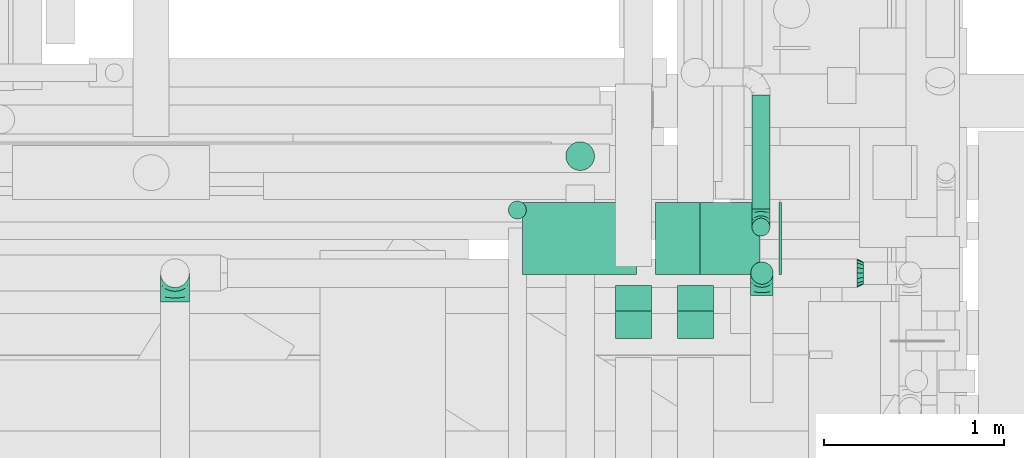
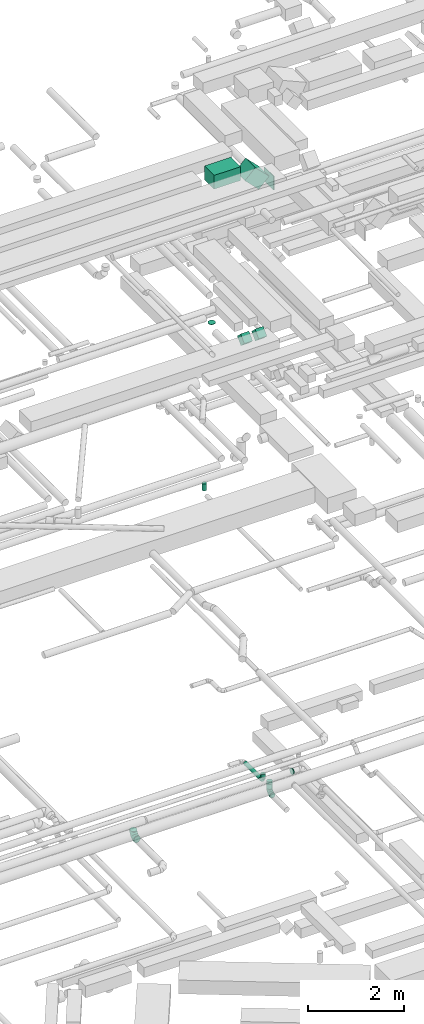
# One storey, part 107 of 337: 10 flow segments, 5 flow fittings.
"""IFC2X3 building model written with IfcOpenShell, lengths in millimetres."""

from ifc_helpers import new_model, entity, si_unit, converted_unit, derived_unit, direction, frame, frame_2d, origin, origin_2d_with_axis, place, context, subcontext, project, spatial, rectangle, circle, extrude, faceted_brep, source, transform, mapped, material, type_object, type_shapes, element, save


model = new_model("IFC2X3")

# Units and contexts
model_context = context("Model", 3, precision=0.01, world=origin(), true_north=direction((6.12303176911189e-17, 1.0)))
body_context = subcontext(model_context, "Body", "Model", "MODEL_VIEW")
ifc_project = project(units=[si_unit("LENGTHUNIT", "METRE", prefix="MILLI"), si_unit("AREAUNIT", "SQUARE_METRE"), si_unit("VOLUMEUNIT", "CUBIC_METRE"), converted_unit("PLANEANGLEUNIT", "DEGREE", entity("IfcRatioMeasure", 0.0174532925199433), si_unit("PLANEANGLEUNIT", "RADIAN"), dimensions=[0, 0, 0, 0, 0, 0, 0]), si_unit("MASSUNIT", "GRAM", prefix="KILO"), derived_unit("MASSDENSITYUNIT", [(si_unit("MASSUNIT", "GRAM", prefix="KILO"), 1), (si_unit("LENGTHUNIT", "METRE"), -3)]), derived_unit("MOMENTOFINERTIAUNIT", [(si_unit("LENGTHUNIT", "METRE"), 4)]), si_unit("TIMEUNIT", "SECOND"), si_unit("FREQUENCYUNIT", "HERTZ"), si_unit("THERMODYNAMICTEMPERATUREUNIT", "DEGREE_CELSIUS"), derived_unit("THERMALTRANSMITTANCEUNIT", [(si_unit("MASSUNIT", "GRAM", prefix="KILO"), 1), (si_unit("THERMODYNAMICTEMPERATUREUNIT", "KELVIN"), -1), (si_unit("TIMEUNIT", "SECOND"), -3)]), derived_unit("VOLUMETRICFLOWRATEUNIT", [(si_unit("LENGTHUNIT", "METRE"), 3), (si_unit("TIMEUNIT", "SECOND"), -1)]), derived_unit("MASSFLOWRATEUNIT", [(si_unit("MASSUNIT", "GRAM", prefix="KILO"), 1), (si_unit("TIMEUNIT", "SECOND"), -1)]), derived_unit("ROTATIONALFREQUENCYUNIT", [(si_unit("TIMEUNIT", "SECOND"), -1)]), si_unit("ELECTRICCURRENTUNIT", "AMPERE"), si_unit("ELECTRICVOLTAGEUNIT", "VOLT"), si_unit("POWERUNIT", "WATT"), si_unit("FORCEUNIT", "NEWTON", prefix="KILO"), si_unit("ILLUMINANCEUNIT", "LUX"), si_unit("LUMINOUSFLUXUNIT", "LUMEN"), si_unit("LUMINOUSINTENSITYUNIT", "CANDELA"), derived_unit("USERDEFINED", [(si_unit("MASSUNIT", "GRAM", prefix="KILO"), -1), (si_unit("LENGTHUNIT", "METRE"), -2), (si_unit("TIMEUNIT", "SECOND"), 3), (si_unit("LUMINOUSFLUXUNIT", "LUMEN"), 1)]), derived_unit("LINEARVELOCITYUNIT", [(si_unit("LENGTHUNIT", "METRE"), 1), (si_unit("TIMEUNIT", "SECOND"), -1)]), si_unit("PRESSUREUNIT", "PASCAL"), derived_unit("USERDEFINED", [(si_unit("LENGTHUNIT", "METRE"), -2), (si_unit("MASSUNIT", "GRAM", prefix="KILO"), 1), (si_unit("TIMEUNIT", "SECOND"), -2)]), derived_unit("LINEARFORCEUNIT", [(si_unit("MASSUNIT", "GRAM", prefix="KILO"), 1), (si_unit("LENGTHUNIT", "METRE"), 1), (si_unit("TIMEUNIT", "SECOND"), -2), (si_unit("LENGTHUNIT", "METRE"), -1)]), derived_unit("PLANARFORCEUNIT", [(si_unit("MASSUNIT", "GRAM", prefix="KILO"), 1), (si_unit("LENGTHUNIT", "METRE"), 1), (si_unit("TIMEUNIT", "SECOND"), -2), (si_unit("LENGTHUNIT", "METRE"), -2)])], contexts=[model_context])

# Site, building, storey
site_placement = place(None, origin())
site = spatial("IfcSite", under=ifc_project, at=site_placement, CompositionType="ELEMENT")
building_placement = place(site_placement, origin())
building = spatial("IfcBuilding", under=site, at=building_placement, CompositionType="ELEMENT")
storey_placement = place(building_placement, origin())
storey = spatial("IfcBuildingStorey", under=building, at=storey_placement, CompositionType="ELEMENT", Elevation=0.0)

# Flow segments
duct_segment_type_1 = type_object("IfcDuctSegmentType", PredefinedType="NOTDEFINED")
flow_segment_1_placement = place(storey_placement, frame((17693.85, 12067.41, 18500.0)))
element("IfcFlowSegment", 1, at=flow_segment_1_placement, inside=storey, type_object=duct_segment_type_1, context=body_context, shape_type="SweptSolid", body=[
    extrude(rectangle(XDim=15.3805922287345, YDim=400.0, at=origin_2d_with_axis()), frame((7.69, 200.0, 0.0), z_axis=(0.0, 0.0, 1.0), x_axis=(-1.0, 0.0, 0.0)), (0.0, 0.0, 1.0), 349.999999999998),
])
flow_segment_2_placement = place(storey_placement, frame((16266.85, 12067.41, 19025.0)))
element("IfcFlowSegment", 2, at=flow_segment_2_placement, inside=storey, type_object=duct_segment_type_1, context=body_context, shape_type="SweptSolid", body=[
    extrude(rectangle(XDim=632.755592228713, YDim=400.0, at=origin_2d_with_axis()), frame((316.38, 200.0, 0.0), z_axis=(0.0, 0.0, 1.0), x_axis=(-1.0, 0.0, 0.0)), (0.0, 0.0, 1.0), 349.999999999998),
])
flow_segment_3_placement = place(storey_placement, frame((17005.67, 12067.41, 18646.45)))
element("IfcFlowSegment", 3, at=flow_segment_3_placement, inside=storey, type_object=duct_segment_type_1, context=body_context, shape_type="SweptSolid", body=[
    extrude(rectangle(XDim=350.000000000003, YDim=400.0, at=origin_2d_with_axis()), frame((123.74, 200.0, 458.36), z_axis=(0.707106781186548, 0.0, -0.707106781186548), x_axis=(0.707106781186548, 0.0, 0.707106781186548)), (0.0, 0.0, 1.0), 473.223304703305),
])
flow_segment_4_placement = place(storey_placement, frame((17130.0, 11710.77, 15002.51)))
element("IfcFlowSegment", 4, at=flow_segment_4_placement, inside=storey, type_object=duct_segment_type_1, context=body_context, shape_type="SweptSolid", body=[
    extrude(rectangle(XDim=200.000000000001, YDim=199.999999999998, at=frame_2d((0.0, 0.0), x_axis=(0.0, 1.0))), frame((100.0, 70.71, 70.71), z_axis=(0.0, 0.707106781186526, 0.707106781186569), x_axis=(-1.0, 0.0, 0.0)), (0.0, 0.0, 1.0), 217.157280798671),
])
flow_segment_5_placement = place(storey_placement, frame((16784.94, 11710.77, 15002.51)))
element("IfcFlowSegment", 5, at=flow_segment_5_placement, inside=storey, type_object=duct_segment_type_1, context=body_context, shape_type="SweptSolid", body=[
    extrude(rectangle(XDim=200.000000000003, YDim=199.999999999998, at=frame_2d((0.0, 0.0), x_axis=(0.0, 1.0))), frame((100.0, 70.71, 70.71), z_axis=(0.0, 0.70710678118652, 0.707106781186575), x_axis=(-1.0, 0.0, 0.0)), (0.0, 0.0, 1.0), 217.157280798674),
])
duct_segment_type_2 = type_object("IfcDuctSegmentType", PredefinedType="NOTDEFINED")
flow_segment_6_placement = place(storey_placement, frame((17542.06, 12430.36, 3348.4)))
element("IfcFlowSegment", 6, at=flow_segment_6_placement, inside=storey, type_object=duct_segment_type_2, context=body_context, shape_type="SweptSolid", body=[
    extrude(circle(Radius=50.0, at=origin_2d_with_axis()), frame((51.6, 0.0, 51.6), z_axis=(0.0, 1.0, 0.0), x_axis=(-1.0, 0.0, 0.0)), (0.0, 0.0, 1.0), 635.000000000009),
])
flow_segment_7_placement = place(storey_placement, frame((16185.99, 12374.09, 11200.0)))
element("IfcFlowSegment", 7, at=flow_segment_7_placement, inside=storey, type_object=duct_segment_type_2, context=body_context, shape_type="SweptSolid", body=[
    extrude(circle(Radius=50.0, at=origin_2d_with_axis()), frame((51.6, 51.6, 0.0)), (0.0, 0.0, 1.0), 169.999999999974),
])
flow_segment_8_placement = place(storey_placement, frame((16505.63, 12644.09, 15130.0)))
element("IfcFlowSegment", 8, at=flow_segment_8_placement, inside=storey, type_object=duct_segment_type_2, context=body_context, shape_type="SweptSolid", body=[
    extrude(circle(Radius=80.0, at=origin_2d_with_axis()), frame((81.6, 81.6, 0.0), z_axis=(0.0, 0.0, 1.0), x_axis=(0.0, 1.0, 0.0)), (0.0, 0.0, 1.0), 10.000064149027),
])
flow_segment_9_placement = place(storey_placement, frame((17535.1, 12010.44, 3375.0)))
element("IfcFlowSegment", 9, at=flow_segment_9_placement, inside=storey, type_object=duct_segment_type_2, context=body_context, shape_type="SweptSolid", body=[
    extrude(circle(Radius=62.5, at=origin_2d_with_axis()), frame((64.1, 64.1, 0.0), z_axis=(0.0, 0.0, 1.0), x_axis=(-1.0, 0.0, 0.0)), (0.0, 0.0, 1.0), 124.999999999998),
])
flow_segment_10_placement = place(storey_placement, frame((17542.06, 12278.76, 3500.0)))
element("IfcFlowSegment", 10, at=flow_segment_10_placement, inside=storey, type_object=duct_segment_type_2, context=body_context, shape_type="SweptSolid", body=[
    extrude(circle(Radius=50.0, at=origin_2d_with_axis()), frame((51.6, 51.6, 0.0)), (0.0, 0.0, 1.0), 84.1742430504415),
])

# Flow fittings
ifc_material = material()
duct_fitting_type_1 = type_object("IfcDuctFittingType", PredefinedType="NOTDEFINED", material=ifc_material)
shared_shape_1 = source(origin(), body_context, "Body", "Brep", [
    faceted_brep([(-160.0, 0.0, -80.0), (-160.0, -20.71, -77.27), (-160.0, -40.0, -69.28), (-160.0, -56.57, -56.57), (-160.0, -69.28, -40.0), (-160.0, -77.27, -20.71), (-160.0, -80.0, 0.0), (-160.0, -77.27, 20.71), (-160.0, -69.28, 40.0), (-160.0, -56.57, 56.57), (-160.0, -40.0, 69.28), (-160.0, -20.71, 77.27), (-160.0, 0.0, 80.0), (-160.0, 20.71, 77.27), (-160.0, 40.0, 69.28), (-160.0, 56.57, 56.57), (-160.0, 69.28, 40.0), (-160.0, 77.27, 20.71), (-160.0, 80.0, 0.0), (-160.0, 77.27, -20.71), (-160.0, 69.28, -40.0), (-160.0, 56.57, -56.57), (-160.0, 40.0, -69.28), (-160.0, 20.71, -77.27), (-122.68, 20.71, 77.27), (-127.85, 40.0, 69.28), (-117.13, 0.0, 80.0), (-132.29, 56.57, 56.57), (-137.83, 77.27, 20.71), (-138.56, 80.0, 0.0), (-135.69, 69.28, 40.0), (-135.69, 69.28, -40.0), (-132.29, 56.57, -56.57), (-137.83, 77.27, -20.71), (-122.68, 20.71, -77.27), (-117.13, 0.0, -80.0), (-127.85, 40.0, -69.28), (-111.58, -20.71, -77.27), (-106.41, -40.0, -69.28), (-101.97, -56.57, -56.57), (-98.56, -69.28, -40.0), (-96.42, -77.27, -20.71), (-95.69, -80.0, 0.0), (-96.42, -77.27, 20.71), (-98.56, -69.28, 40.0), (-101.97, -56.57, 56.57), (-106.41, -40.0, 69.28), (-111.58, -20.71, 77.27), (-58.03, 58.03, 77.27), (-72.15, 72.15, 69.28), (-42.87, 42.87, 80.0), (-84.28, 84.28, 56.57), (-93.59, 93.59, 40.0), (-99.44, 99.44, 20.71), (-101.44, 101.44, 0.0), (-99.44, 99.44, -20.71), (-93.59, 93.59, -40.0), (-84.28, 84.28, -56.57), (-58.03, 58.03, -77.27), (-42.87, 42.87, -80.0), (-72.15, 72.15, -69.28), (-27.71, 27.71, -77.27), (-13.59, 13.59, -69.28), (-1.46, 1.46, -56.57), (7.85, -7.85, -40.0), (13.7, -13.7, -20.71), (15.69, -15.69, 0.0), (13.7, -13.7, 20.71), (7.85, -7.85, 40.0), (-1.46, 1.46, 56.57), (-13.59, 13.59, 69.28), (-27.71, 27.71, 77.27), (-20.71, 122.68, 77.27), (-40.0, 127.85, 69.28), (0.0, 117.13, 80.0), (-56.57, 132.29, 56.57), (-69.28, 135.69, 40.0), (-77.27, 137.83, 20.71), (-80.0, 138.56, 0.0), (-77.27, 137.83, -20.71), (-69.28, 135.69, -40.0), (-56.57, 132.29, -56.57), (-20.71, 122.68, -77.27), (0.0, 117.13, -80.0), (-40.0, 127.85, -69.28), (20.71, 111.58, -77.27), (40.0, 106.41, -69.28), (56.57, 101.97, -56.57), (69.28, 98.56, -40.0), (77.27, 96.42, -20.71), (80.0, 95.69, 0.0), (77.27, 96.42, 20.71), (69.28, 98.56, 40.0), (56.57, 101.97, 56.57), (40.0, 106.41, 69.28), (20.71, 111.58, 77.27), (-20.71, 160.0, -77.27), (-40.0, 160.0, -69.28), (-56.57, 160.0, -56.57), (-69.28, 160.0, -40.0), (-77.27, 160.0, -20.71), (-80.0, 160.0, 0.0), (-77.27, 160.0, 20.71), (-69.28, 160.0, 40.0), (-56.57, 160.0, 56.57), (-40.0, 160.0, 69.28), (-20.71, 160.0, 77.27), (0.0, 160.0, 80.0), (20.71, 160.0, 77.27), (40.0, 160.0, 69.28), (56.57, 160.0, 56.57), (69.28, 160.0, 40.0), (77.27, 160.0, 20.71), (80.0, 160.0, 0.0), (77.27, 160.0, -20.71), (69.28, 160.0, -40.0), (56.57, 160.0, -56.57), (40.0, 160.0, -69.28), (20.71, 160.0, -77.27), (0.0, 160.0, -80.0)], [[[0, 1, 2, 3, 4, 5, 6, 7, 8, 9, 10, 11, 12, 13, 14, 15, 16, 17, 18, 19, 20, 21, 22, 23]], [[24, 25, 14, 13]], [[26, 24, 13, 12]], [[14, 25, 27, 15]], [[28, 29, 18, 17]], [[30, 28, 17, 16]], [[15, 27, 30, 16]], [[20, 31, 32, 21]], [[33, 31, 20, 19]], [[18, 29, 33, 19]], [[34, 35, 0, 23]], [[36, 34, 23, 22]], [[32, 36, 22, 21]], [[1, 0, 35, 37]], [[2, 1, 37, 38]], [[3, 2, 38, 39]], [[5, 4, 40, 41]], [[6, 5, 41, 42]], [[39, 40, 4, 3]], [[6, 42, 43, 7]], [[7, 43, 44, 8]], [[8, 44, 45, 9]], [[9, 45, 46, 10]], [[10, 46, 47, 11]], [[26, 12, 11, 47]], [[48, 49, 25, 24]], [[50, 48, 24, 26]], [[27, 25, 49, 51]], [[52, 53, 28, 30]], [[51, 52, 30, 27]], [[29, 28, 53, 54]], [[55, 56, 31, 33]], [[54, 55, 33, 29]], [[32, 31, 56, 57]], [[58, 59, 35, 34]], [[60, 58, 34, 36]], [[57, 60, 36, 32]], [[37, 35, 59, 61]], [[38, 37, 61, 62]], [[39, 38, 62, 63]], [[41, 40, 64, 65]], [[42, 41, 65, 66]], [[63, 64, 40, 39]], [[43, 42, 66, 67]], [[44, 43, 67, 68]], [[68, 69, 45, 44]], [[46, 45, 69, 70]], [[47, 46, 70, 71]], [[26, 47, 71, 50]], [[72, 73, 49, 48]], [[74, 72, 48, 50]], [[51, 49, 73, 75]], [[76, 77, 53, 52]], [[75, 76, 52, 51]], [[54, 53, 77, 78]], [[79, 80, 56, 55]], [[78, 79, 55, 54]], [[57, 56, 80, 81]], [[82, 83, 59, 58]], [[84, 82, 58, 60]], [[81, 84, 60, 57]], [[61, 59, 83, 85]], [[62, 61, 85, 86]], [[63, 62, 86, 87]], [[65, 64, 88, 89]], [[66, 65, 89, 90]], [[87, 88, 64, 63]], [[67, 66, 90, 91]], [[68, 67, 91, 92]], [[92, 93, 69, 68]], [[70, 69, 93, 94]], [[71, 70, 94, 95]], [[50, 71, 95, 74]], [[96, 97, 98, 99, 100, 101, 102, 103, 104, 105, 106, 107, 108, 109, 110, 111, 112, 113, 114, 115, 116, 117, 118, 119]], [[72, 74, 107, 106]], [[73, 72, 106, 105]], [[75, 73, 105, 104]], [[77, 76, 103, 102]], [[78, 77, 102, 101]], [[75, 104, 103, 76]], [[78, 101, 100, 79]], [[79, 100, 99, 80]], [[80, 99, 98, 81]], [[84, 97, 96, 82]], [[82, 96, 119, 83]], [[84, 81, 98, 97]], [[118, 117, 86, 85]], [[119, 118, 85, 83]], [[116, 87, 86, 117]], [[88, 115, 114, 89]], [[89, 114, 113, 90]], [[115, 88, 87, 116]], [[112, 111, 92, 91]], [[113, 112, 91, 90]], [[111, 110, 93, 92]], [[95, 94, 109, 108]], [[74, 95, 108, 107]], [[110, 109, 94, 93]]]),
])
type_shapes(duct_fitting_type_1, [shared_shape_1])
flow_fitting_1_placement = place(storey_placement, frame((14331.42, 12074.54, 3300.0), z_axis=(-1.0, 0.0, 0.0), x_axis=(0.0, 0.0, -1.0)))
element("IfcFlowFitting", 11, at=flow_fitting_1_placement, inside=storey, type_object=duct_fitting_type_1, material=ifc_material, context=body_context, shape_type="MappedRepresentation", body=[
    mapped(shared_shape_1, transform((0.0, 0.0, 0.0), scale=1.0)),
])
duct_fitting_type_2 = type_object("IfcDuctFittingType", PredefinedType="NOTDEFINED", material=ifc_material)
shared_shape_2 = source(origin(), body_context, "Body", "Brep", [
    faceted_brep([(-100.0, 0.0, -50.0), (-100.0, -12.94, -48.3), (-100.0, -25.0, -43.3), (-100.0, -35.36, -35.36), (-100.0, -43.3, -25.0), (-100.0, -48.3, -12.94), (-100.0, -50.0, 0.0), (-100.0, -48.3, 12.94), (-100.0, -43.3, 25.0), (-100.0, -35.36, 35.36), (-100.0, -25.0, 43.3), (-100.0, -12.94, 48.3), (-100.0, 0.0, 50.0), (-100.0, 12.94, 48.3), (-100.0, 25.0, 43.3), (-100.0, 35.36, 35.36), (-100.0, 43.3, 25.0), (-100.0, 48.3, 12.94), (-100.0, 50.0, 0.0), (-100.0, 48.3, -12.94), (-100.0, 43.3, -25.0), (-100.0, 35.36, -35.36), (-100.0, 25.0, -43.3), (-100.0, 12.94, -48.3), (-76.67, 12.94, 48.3), (-79.9, 25.0, 43.3), (-73.21, 0.0, 50.0), (-82.68, 35.36, 35.36), (-86.15, 48.3, 12.94), (-86.6, 50.0, 0.0), (-84.81, 43.3, 25.0), (-84.81, 43.3, -25.0), (-82.68, 35.36, -35.36), (-86.15, 48.3, -12.94), (-76.67, 12.94, -48.3), (-73.21, 0.0, -50.0), (-79.9, 25.0, -43.3), (-69.74, -12.94, -48.3), (-66.51, -25.0, -43.3), (-63.73, -35.36, -35.36), (-61.6, -43.3, -25.0), (-60.26, -48.3, -12.94), (-59.81, -50.0, 0.0), (-60.26, -48.3, 12.94), (-61.6, -43.3, 25.0), (-63.73, -35.36, 35.36), (-66.51, -25.0, 43.3), (-69.74, -12.94, 48.3), (-36.27, 36.27, 48.3), (-45.1, 45.1, 43.3), (-26.79, 26.79, 50.0), (-52.68, 52.68, 35.36), (-58.49, 58.49, 25.0), (-62.15, 62.15, 12.94), (-63.4, 63.4, 0.0), (-62.15, 62.15, -12.94), (-58.49, 58.49, -25.0), (-52.68, 52.68, -35.36), (-36.27, 36.27, -48.3), (-26.79, 26.79, -50.0), (-45.1, 45.1, -43.3), (-17.32, 17.32, -48.3), (-8.49, 8.49, -43.3), (-0.91, 0.91, -35.36), (4.9, -4.9, -25.0), (8.56, -8.56, -12.94), (9.81, -9.81, 0.0), (8.56, -8.56, 12.94), (4.9, -4.9, 25.0), (-0.91, 0.91, 35.36), (-8.49, 8.49, 43.3), (-17.32, 17.32, 48.3), (-12.94, 76.67, 48.3), (-25.0, 79.9, 43.3), (0.0, 73.21, 50.0), (-35.36, 82.68, 35.36), (-43.3, 84.81, 25.0), (-48.3, 86.15, 12.94), (-50.0, 86.6, 0.0), (-48.3, 86.15, -12.94), (-43.3, 84.81, -25.0), (-35.36, 82.68, -35.36), (-12.94, 76.67, -48.3), (0.0, 73.21, -50.0), (-25.0, 79.9, -43.3), (12.94, 69.74, -48.3), (25.0, 66.51, -43.3), (35.36, 63.73, -35.36), (43.3, 61.6, -25.0), (48.3, 60.26, -12.94), (50.0, 59.81, 0.0), (48.3, 60.26, 12.94), (43.3, 61.6, 25.0), (35.36, 63.73, 35.36), (25.0, 66.51, 43.3), (12.94, 69.74, 48.3), (-12.94, 100.0, -48.3), (-25.0, 100.0, -43.3), (-35.36, 100.0, -35.36), (-43.3, 100.0, -25.0), (-48.3, 100.0, -12.94), (-50.0, 100.0, 0.0), (-48.3, 100.0, 12.94), (-43.3, 100.0, 25.0), (-35.36, 100.0, 35.36), (-25.0, 100.0, 43.3), (-12.94, 100.0, 48.3), (0.0, 100.0, 50.0), (12.94, 100.0, 48.3), (25.0, 100.0, 43.3), (35.36, 100.0, 35.36), (43.3, 100.0, 25.0), (48.3, 100.0, 12.94), (50.0, 100.0, 0.0), (48.3, 100.0, -12.94), (43.3, 100.0, -25.0), (35.36, 100.0, -35.36), (25.0, 100.0, -43.3), (12.94, 100.0, -48.3), (0.0, 100.0, -50.0)], [[[0, 1, 2, 3, 4, 5, 6, 7, 8, 9, 10, 11, 12, 13, 14, 15, 16, 17, 18, 19, 20, 21, 22, 23]], [[24, 25, 14, 13]], [[26, 24, 13, 12]], [[14, 25, 27, 15]], [[28, 29, 18, 17]], [[30, 28, 17, 16]], [[15, 27, 30, 16]], [[20, 31, 32, 21]], [[33, 31, 20, 19]], [[18, 29, 33, 19]], [[34, 35, 0, 23]], [[36, 34, 23, 22]], [[32, 36, 22, 21]], [[2, 1, 37, 38]], [[3, 2, 38, 39]], [[0, 35, 37, 1]], [[5, 4, 40, 41]], [[6, 5, 41, 42]], [[3, 39, 40, 4]], [[6, 42, 43, 7]], [[7, 43, 44, 8]], [[8, 44, 45, 9]], [[10, 46, 47, 11]], [[11, 47, 26, 12]], [[10, 9, 45, 46]], [[48, 49, 25, 24]], [[50, 48, 24, 26]], [[27, 25, 49, 51]], [[52, 53, 28, 30]], [[51, 52, 30, 27]], [[29, 28, 53, 54]], [[55, 56, 31, 33]], [[54, 55, 33, 29]], [[57, 32, 31, 56]], [[58, 59, 35, 34]], [[60, 58, 34, 36]], [[57, 60, 36, 32]], [[37, 35, 59, 61]], [[38, 37, 61, 62]], [[39, 38, 62, 63]], [[41, 40, 64, 65]], [[42, 41, 65, 66]], [[63, 64, 40, 39]], [[43, 42, 66, 67]], [[44, 43, 67, 68]], [[68, 69, 45, 44]], [[46, 45, 69, 70]], [[47, 46, 70, 71]], [[26, 47, 71, 50]], [[72, 73, 49, 48]], [[74, 72, 48, 50]], [[51, 49, 73, 75]], [[76, 77, 53, 52]], [[75, 76, 52, 51]], [[54, 53, 77, 78]], [[79, 80, 56, 55]], [[78, 79, 55, 54]], [[81, 57, 56, 80]], [[82, 83, 59, 58]], [[84, 82, 58, 60]], [[81, 84, 60, 57]], [[61, 59, 83, 85]], [[62, 61, 85, 86]], [[63, 62, 86, 87]], [[65, 64, 88, 89]], [[66, 65, 89, 90]], [[87, 88, 64, 63]], [[67, 66, 90, 91]], [[68, 67, 91, 92]], [[92, 93, 69, 68]], [[70, 69, 93, 94]], [[71, 70, 94, 95]], [[50, 71, 95, 74]], [[96, 97, 98, 99, 100, 101, 102, 103, 104, 105, 106, 107, 108, 109, 110, 111, 112, 113, 114, 115, 116, 117, 118, 119]], [[72, 74, 107, 106]], [[73, 72, 106, 105]], [[75, 73, 105, 104]], [[77, 76, 103, 102]], [[78, 77, 102, 101]], [[75, 104, 103, 76]], [[78, 101, 100, 79]], [[79, 100, 99, 80]], [[80, 99, 98, 81]], [[96, 119, 83, 82]], [[97, 96, 82, 84]], [[84, 81, 98, 97]], [[83, 119, 118, 85]], [[85, 118, 117, 86]], [[86, 117, 116, 87]], [[88, 115, 114, 89]], [[89, 114, 113, 90]], [[87, 116, 115, 88]], [[91, 90, 113, 112]], [[92, 91, 112, 111]], [[93, 92, 111, 110]], [[95, 94, 109, 108]], [[74, 95, 108, 107]], [[110, 109, 94, 93]]]),
])
type_shapes(duct_fitting_type_2, [shared_shape_2])
flow_fitting_2_placement = place(storey_placement, frame((17593.66, 12330.36, 3400.0), z_axis=(1.0, 0.0, 0.0), x_axis=(0.0, 0.0, -1.0)))
element("IfcFlowFitting", 12, at=flow_fitting_2_placement, inside=storey, type_object=duct_fitting_type_2, material=ifc_material, context=body_context, shape_type="MappedRepresentation", body=[
    mapped(shared_shape_2, transform((0.0, 0.0, 0.0), scale=1.0)),
])
duct_fitting_type_3 = type_object("IfcDuctFittingType", PredefinedType="NOTDEFINED", material=ifc_material)
shared_shape_3 = source(origin(), body_context, "Body", "Brep", [
    faceted_brep([(-125.0, 0.0, -62.5), (-125.0, -16.18, -60.37), (-125.0, -31.25, -54.13), (-125.0, -44.19, -44.19), (-125.0, -54.13, -31.25), (-125.0, -60.37, -16.18), (-125.0, -62.5, 0.0), (-125.0, -60.37, 16.18), (-125.0, -54.13, 31.25), (-125.0, -44.19, 44.19), (-125.0, -31.25, 54.13), (-125.0, -16.18, 60.37), (-125.0, 0.0, 62.5), (-125.0, 16.18, 60.37), (-125.0, 31.25, 54.13), (-125.0, 44.19, 44.19), (-125.0, 54.13, 31.25), (-125.0, 60.37, 16.18), (-125.0, 62.5, 0.0), (-125.0, 60.37, -16.18), (-125.0, 54.13, -31.25), (-125.0, 44.19, -44.19), (-125.0, 31.25, -54.13), (-125.0, 16.18, -60.37), (-95.84, 16.18, 60.37), (-99.88, 31.25, 54.13), (-91.51, 0.0, 62.5), (-103.35, 44.19, 44.19), (-107.68, 60.37, 16.18), (-108.25, 62.5, 0.0), (-106.01, 54.13, 31.25), (-106.01, 54.13, -31.25), (-103.35, 44.19, -44.19), (-107.68, 60.37, -16.18), (-95.84, 16.18, -60.37), (-91.51, 0.0, -62.5), (-99.88, 31.25, -54.13), (-87.17, -16.18, -60.37), (-83.13, -31.25, -54.13), (-79.66, -44.19, -44.19), (-77.0, -54.13, -31.25), (-75.33, -60.37, -16.18), (-74.76, -62.5, 0.0), (-75.33, -60.37, 16.18), (-77.0, -54.13, 31.25), (-79.66, -44.19, 44.19), (-83.13, -31.25, 54.13), (-87.17, -16.18, 60.37), (-45.34, 45.34, 60.37), (-56.37, 56.37, 54.13), (-33.49, 33.49, 62.5), (-65.85, 65.85, 44.19), (-73.12, 73.12, 31.25), (-77.69, 77.69, 16.18), (-79.25, 79.25, 0.0), (-77.69, 77.69, -16.18), (-73.12, 73.12, -31.25), (-65.85, 65.85, -44.19), (-45.34, 45.34, -60.37), (-33.49, 33.49, -62.5), (-56.37, 56.37, -54.13), (-21.65, 21.65, -60.37), (-10.62, 10.62, -54.13), (-1.14, 1.14, -44.19), (6.13, -6.13, -31.25), (10.7, -10.7, -16.18), (12.26, -12.26, 0.0), (10.7, -10.7, 16.18), (6.13, -6.13, 31.25), (-1.14, 1.14, 44.19), (-10.62, 10.62, 54.13), (-21.65, 21.65, 60.37), (-16.18, 95.84, 60.37), (-31.25, 99.88, 54.13), (0.0, 91.51, 62.5), (-44.19, 103.35, 44.19), (-54.13, 106.01, 31.25), (-60.37, 107.68, 16.18), (-62.5, 108.25, 0.0), (-60.37, 107.68, -16.18), (-54.13, 106.01, -31.25), (-44.19, 103.35, -44.19), (-16.18, 95.84, -60.37), (0.0, 91.51, -62.5), (-31.25, 99.88, -54.13), (16.18, 87.17, -60.37), (31.25, 83.13, -54.13), (44.19, 79.66, -44.19), (54.13, 77.0, -31.25), (60.37, 75.33, -16.18), (62.5, 74.76, 0.0), (60.37, 75.33, 16.18), (54.13, 77.0, 31.25), (44.19, 79.66, 44.19), (31.25, 83.13, 54.13), (16.18, 87.17, 60.37), (-16.18, 125.0, -60.37), (-31.25, 125.0, -54.13), (-44.19, 125.0, -44.19), (-54.13, 125.0, -31.25), (-60.37, 125.0, -16.18), (-62.5, 125.0, 0.0), (-60.37, 125.0, 16.18), (-54.13, 125.0, 31.25), (-44.19, 125.0, 44.19), (-31.25, 125.0, 54.13), (-16.18, 125.0, 60.37), (0.0, 125.0, 62.5), (16.18, 125.0, 60.37), (31.25, 125.0, 54.13), (44.19, 125.0, 44.19), (54.13, 125.0, 31.25), (60.37, 125.0, 16.18), (62.5, 125.0, 0.0), (60.37, 125.0, -16.18), (54.13, 125.0, -31.25), (44.19, 125.0, -44.19), (31.25, 125.0, -54.13), (16.18, 125.0, -60.37), (0.0, 125.0, -62.5)], [[[0, 1, 2, 3, 4, 5, 6, 7, 8, 9, 10, 11, 12, 13, 14, 15, 16, 17, 18, 19, 20, 21, 22, 23]], [[24, 25, 14, 13]], [[26, 24, 13, 12]], [[14, 25, 27, 15]], [[28, 29, 18, 17]], [[30, 28, 17, 16]], [[15, 27, 30, 16]], [[20, 31, 32, 21]], [[33, 31, 20, 19]], [[18, 29, 33, 19]], [[34, 35, 0, 23]], [[36, 34, 23, 22]], [[21, 32, 36, 22]], [[1, 0, 35, 37]], [[2, 1, 37, 38]], [[38, 39, 3, 2]], [[5, 4, 40, 41]], [[6, 5, 41, 42]], [[39, 40, 4, 3]], [[6, 42, 43, 7]], [[7, 43, 44, 8]], [[45, 9, 8, 44]], [[9, 45, 46, 10]], [[10, 46, 47, 11]], [[26, 12, 11, 47]], [[48, 49, 25, 24]], [[50, 48, 24, 26]], [[27, 25, 49, 51]], [[52, 53, 28, 30]], [[51, 52, 30, 27]], [[29, 28, 53, 54]], [[55, 56, 31, 33]], [[54, 55, 33, 29]], [[57, 32, 31, 56]], [[58, 59, 35, 34]], [[60, 58, 34, 36]], [[57, 60, 36, 32]], [[37, 35, 59, 61]], [[38, 37, 61, 62]], [[39, 38, 62, 63]], [[41, 40, 64, 65]], [[42, 41, 65, 66]], [[63, 64, 40, 39]], [[43, 42, 66, 67]], [[44, 43, 67, 68]], [[68, 69, 45, 44]], [[46, 45, 69, 70]], [[47, 46, 70, 71]], [[26, 47, 71, 50]], [[72, 73, 49, 48]], [[74, 72, 48, 50]], [[51, 49, 73, 75]], [[76, 77, 53, 52]], [[75, 76, 52, 51]], [[54, 53, 77, 78]], [[79, 80, 56, 55]], [[78, 79, 55, 54]], [[81, 57, 56, 80]], [[82, 83, 59, 58]], [[84, 82, 58, 60]], [[81, 84, 60, 57]], [[61, 59, 83, 85]], [[62, 61, 85, 86]], [[63, 62, 86, 87]], [[65, 64, 88, 89]], [[66, 65, 89, 90]], [[87, 88, 64, 63]], [[67, 66, 90, 91]], [[68, 67, 91, 92]], [[92, 93, 69, 68]], [[70, 69, 93, 94]], [[71, 70, 94, 95]], [[50, 71, 95, 74]], [[96, 97, 98, 99, 100, 101, 102, 103, 104, 105, 106, 107, 108, 109, 110, 111, 112, 113, 114, 115, 116, 117, 118, 119]], [[72, 74, 107, 106]], [[73, 72, 106, 105]], [[75, 73, 105, 104]], [[77, 76, 103, 102]], [[78, 77, 102, 101]], [[75, 104, 103, 76]], [[78, 101, 100, 79]], [[79, 100, 99, 80]], [[80, 99, 98, 81]], [[96, 119, 83, 82]], [[97, 96, 82, 84]], [[84, 81, 98, 97]], [[83, 119, 118, 85]], [[85, 118, 117, 86]], [[116, 87, 86, 117]], [[88, 115, 114, 89]], [[89, 114, 113, 90]], [[115, 88, 87, 116]], [[91, 90, 113, 112]], [[92, 91, 112, 111]], [[111, 110, 93, 92]], [[95, 94, 109, 108]], [[74, 95, 108, 107]], [[110, 109, 94, 93]]]),
])
type_shapes(duct_fitting_type_3, [shared_shape_3])
flow_fitting_3_placement = place(storey_placement, frame((17599.2, 12074.54, 3250.0), z_axis=(-1.0, 0.0, 0.0), x_axis=(0.0, 0.0, -1.0)))
element("IfcFlowFitting", 13, at=flow_fitting_3_placement, inside=storey, type_object=duct_fitting_type_3, material=ifc_material, context=body_context, shape_type="MappedRepresentation", body=[
    mapped(shared_shape_3, transform((0.0, 0.0, 0.0), scale=1.0)),
])
duct_fitting_type_4 = type_object("IfcDuctFittingType", PredefinedType="NOTDEFINED", material=ifc_material)
shared_shape_4 = source(origin(), body_context, "Body", "Brep", [
    faceted_brep([(35.0, 0.0, -80.0), (35.0, 12.81, -77.45), (35.0, 30.61, -73.91), (35.0, 43.59, -65.24), (35.0, 56.57, -56.57), (35.0, 65.24, -43.59), (35.0, 73.91, -30.61), (35.0, 76.96, -15.31), (35.0, 80.0, 0.0), (35.0, 77.45, 12.81), (35.0, 73.91, 30.61), (35.0, 65.24, 43.59), (35.0, 56.57, 56.57), (35.0, 43.59, 65.24), (35.0, 30.61, 73.91), (35.0, 15.31, 76.96), (35.0, 0.0, 80.0), (35.0, -12.81, 77.45), (35.0, -30.61, 73.91), (35.0, -43.59, 65.24), (35.0, -56.57, 56.57), (35.0, -65.24, 43.59), (35.0, -73.91, 30.61), (35.0, -76.96, 15.31), (35.0, -80.0, 0.0), (35.0, -77.45, -12.81), (35.0, -73.91, -30.61), (35.0, -65.24, -43.59), (35.0, -56.57, -56.57), (35.0, -43.59, -65.24), (35.0, -30.61, -73.91), (35.0, -15.31, -76.96), (0.0, -23.92, -57.74), (0.0, -34.06, -50.97), (0.0, -44.19, -44.19), (0.0, -50.97, -34.06), (0.0, -57.74, -23.92), (0.0, -60.12, -11.96), (0.0, -62.5, 0.0), (0.0, -60.12, 11.96), (0.0, -57.74, 23.92), (0.0, -50.97, 34.06), (0.0, -44.19, 44.19), (0.0, -34.06, 50.97), (0.0, -23.92, 57.74), (0.0, -11.96, 60.12), (0.0, 0.0, 62.5), (0.0, 11.96, 60.12), (0.0, 23.92, 57.74), (0.0, 34.06, 50.97), (0.0, 44.19, 44.19), (0.0, 50.97, 34.06), (0.0, 57.74, 23.92), (0.0, 60.12, 11.96), (0.0, 62.5, 0.0), (0.0, 60.12, -11.96), (0.0, 57.74, -23.92), (0.0, 50.97, -34.06), (0.0, 44.19, -44.19), (0.0, 34.06, -50.97), (0.0, 23.92, -57.74), (0.0, 11.96, -60.12), (0.0, 0.0, -62.5), (0.0, -11.96, -60.12)], [[[0, 1, 2, 3, 4, 5, 6, 7, 8, 9, 10, 11, 12, 13, 14, 15, 16, 17, 18, 19, 20, 21, 22, 23, 24, 25, 26, 27, 28, 29, 30, 31]], [[32, 33, 34, 35, 36, 37, 38, 39, 40, 41, 42, 43, 44, 45, 46, 47, 48, 49, 50, 51, 52, 53, 54, 55, 56, 57, 58, 59, 60, 61, 62, 63]], [[10, 9, 8, 54, 53, 52]], [[11, 10, 52, 51, 50, 12]], [[48, 14, 13, 12, 50, 49]], [[46, 16, 15, 14, 48, 47]], [[18, 17, 16, 46, 45, 44]], [[19, 18, 44, 43, 42, 20]], [[40, 22, 21, 20, 42, 41]], [[38, 24, 23, 22, 40, 39]], [[26, 25, 24, 38, 37, 36]], [[27, 26, 36, 35, 34, 28]], [[32, 30, 29, 28, 34, 33]], [[62, 0, 31, 30, 32, 63]], [[2, 1, 0, 62, 61, 60]], [[3, 2, 60, 59, 58, 4]], [[56, 6, 5, 4, 58, 57]], [[54, 8, 7, 6, 56, 55]]]),
])
type_shapes(duct_fitting_type_4, [shared_shape_4])
flow_fitting_4_placement = place(storey_placement, frame((18164.1, 12074.54, 3600.0), z_axis=(0.0, 0.0, 1.0), x_axis=(-1.0, 0.0, 0.0)))
element("IfcFlowFitting", 14, at=flow_fitting_4_placement, inside=storey, type_object=duct_fitting_type_4, material=ifc_material, context=body_context, shape_type="MappedRepresentation", body=[
    mapped(shared_shape_4, transform((0.0, 0.0, 0.0), scale=1.0)),
])
duct_fitting_type_5 = type_object("IfcDuctFittingType", PredefinedType="NOTDEFINED", material=ifc_material)
shared_shape_5 = source(origin(), body_context, "Body", "Brep", [
    faceted_brep([(20.0, 0.0, -62.5), (20.0, 16.18, -60.37), (20.0, 31.25, -54.13), (20.0, 44.19, -44.19), (20.0, 54.13, -31.25), (20.0, 60.37, -16.18), (20.0, 62.5, 0.0), (20.0, 60.37, 16.18), (20.0, 54.13, 31.25), (20.0, 44.19, 44.19), (20.0, 31.25, 54.13), (20.0, 16.18, 60.37), (20.0, 0.0, 62.5), (20.0, -16.18, 60.37), (20.0, -31.25, 54.13), (20.0, -44.19, 44.19), (20.0, -54.13, 31.25), (20.0, -60.37, 16.18), (20.0, -62.5, 0.0), (20.0, -60.37, -16.18), (20.0, -54.13, -31.25), (20.0, -44.19, -44.19), (20.0, -31.25, -54.13), (20.0, -16.18, -60.37), (0.0, 0.0, 62.5), (-36.16, 0.0, 62.5), (-36.16, -16.18, 60.37), (0.0, -16.18, 60.37), (-36.16, -31.25, 54.13), (0.0, -31.25, 54.13), (0.0, -44.19, 44.19), (-36.16, -44.19, 44.19), (0.0, -54.13, 31.25), (-36.16, -54.13, 31.25), (-36.16, -60.37, 16.18), (0.0, -60.37, 16.18), (-36.16, -62.5, 0.0), (0.0, -62.5, 0.0), (-36.16, -60.37, -16.18), (0.0, -60.37, -16.18), (-36.16, -54.13, -31.25), (0.0, -54.13, -31.25), (0.0, -44.19, -44.19), (-36.16, -44.19, -44.19), (0.0, -31.25, -54.13), (-36.16, -31.25, -54.13), (-36.16, -16.18, -60.37), (0.0, -16.18, -60.37), (-36.16, 0.0, -62.5), (0.0, 0.0, -62.5), (-36.16, 16.18, -60.37), (0.0, 16.18, -60.37), (-36.16, 31.25, -54.13), (0.0, 31.25, -54.13), (0.0, 44.19, -44.19), (-36.16, 44.19, -44.19), (0.0, 54.13, -31.25), (-36.16, 54.13, -31.25), (-36.16, 60.37, -16.18), (0.0, 60.37, -16.18), (-36.16, 62.5, 0.0), (0.0, 62.5, 0.0), (-36.16, 60.37, 16.18), (0.0, 60.37, 16.18), (-36.16, 54.13, 31.25), (0.0, 54.13, 31.25), (0.0, 44.19, 44.19), (-36.16, 44.19, 44.19), (0.0, 31.25, 54.13), (-36.16, 31.25, 54.13), (-36.16, 16.18, 60.37), (0.0, 16.18, 60.37)], [[[0, 1, 2, 3, 4, 5, 6, 7, 8, 9, 10, 11, 12, 13, 14, 15, 16, 17, 18, 19, 20, 21, 22, 23]], [[13, 12, 24, 25, 26, 27]], [[14, 13, 27, 26, 28, 29]], [[30, 15, 14, 29, 28, 31]], [[17, 16, 32, 33, 34, 35]], [[18, 17, 35, 34, 36, 37]], [[32, 16, 15, 30, 31, 33]], [[19, 18, 37, 36, 38, 39]], [[20, 19, 39, 38, 40, 41]], [[42, 21, 20, 41, 40, 43]], [[23, 22, 44, 45, 46, 47]], [[0, 23, 47, 46, 48, 49]], [[44, 22, 21, 42, 43, 45]], [[1, 0, 49, 48, 50, 51]], [[2, 1, 51, 50, 52, 53]], [[54, 3, 2, 53, 52, 55]], [[5, 4, 56, 57, 58, 59]], [[6, 5, 59, 58, 60, 61]], [[56, 4, 3, 54, 55, 57]], [[7, 6, 61, 60, 62, 63]], [[8, 7, 63, 62, 64, 65]], [[66, 9, 8, 65, 64, 67]], [[11, 10, 68, 69, 70, 71]], [[12, 11, 71, 70, 25, 24]], [[68, 10, 9, 66, 67, 69]], [[46, 45, 43, 40, 38, 36, 34, 33, 31, 28, 26, 25, 70, 69, 67, 64, 62, 60, 58, 57, 55, 52, 50, 48]]]),
])
type_shapes(duct_fitting_type_5, [shared_shape_5])
flow_fitting_5_placement = place(storey_placement, frame((17599.2, 12074.54, 3520.0), z_axis=(0.0, -1.0, 0.0), x_axis=(0.0, 0.0, -1.0)))
element("IfcFlowFitting", 15, at=flow_fitting_5_placement, inside=storey, type_object=duct_fitting_type_5, material=ifc_material, context=body_context, shape_type="MappedRepresentation", body=[
    mapped(shared_shape_5, transform((0.0, 0.0, 0.0), scale=1.0)),
])

save(model, "model.ifc")
